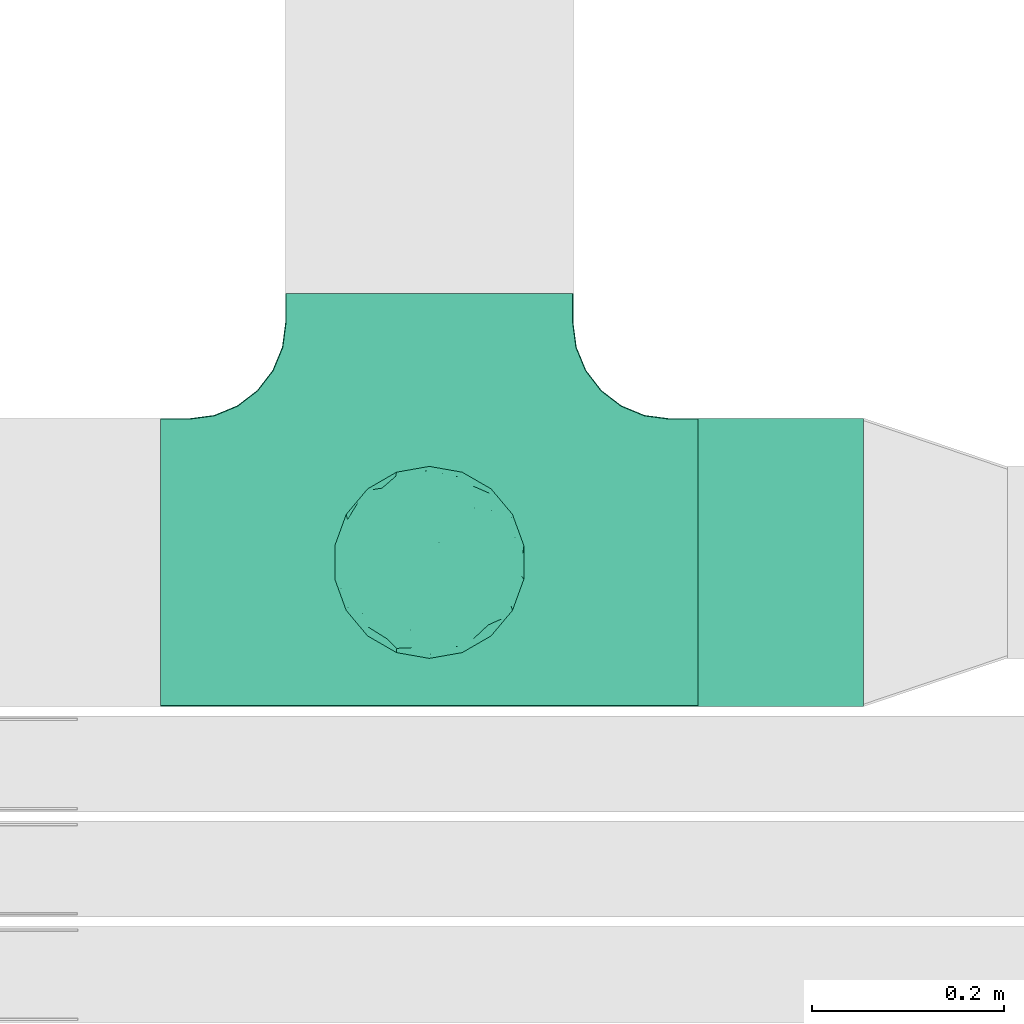
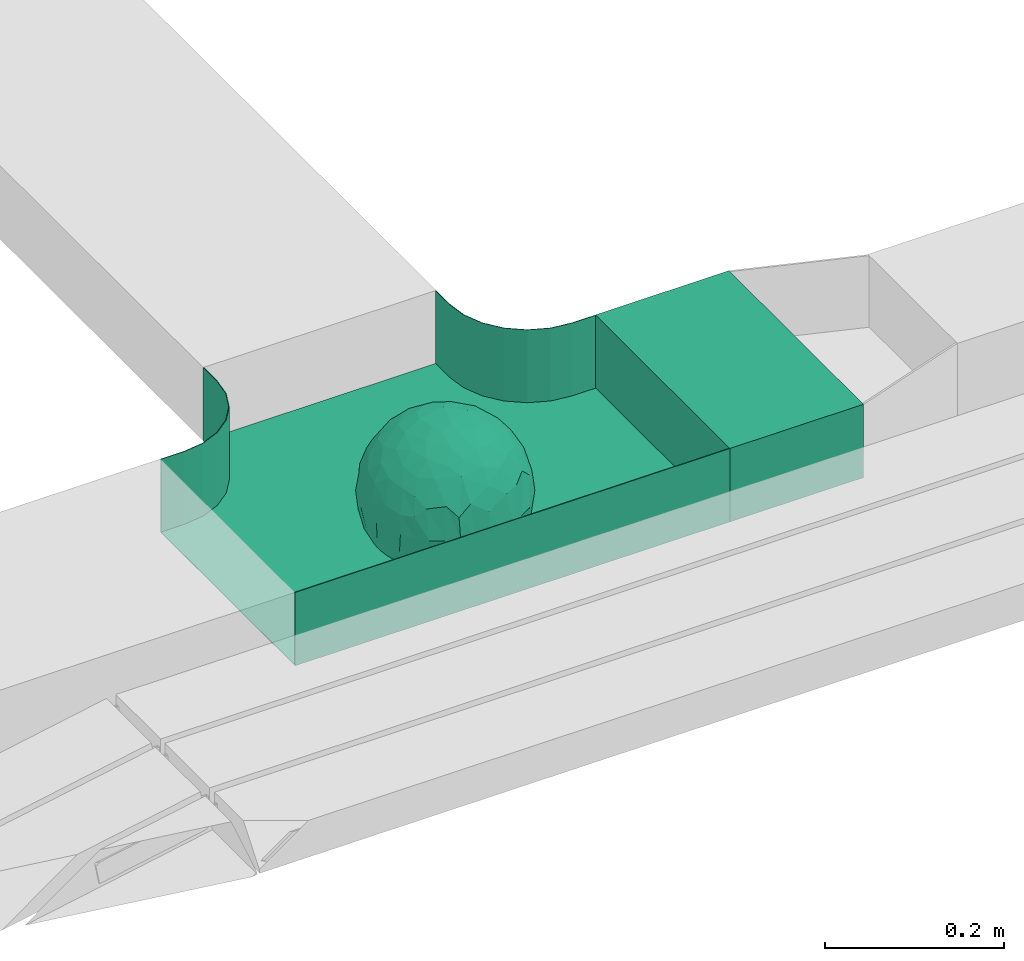
# One storey, part 12 of 33: 1 flow fitting, 1 flow segment.
"""IFC2X3 building model written with IfcOpenShell, lengths in millimetres."""

from ifc_helpers import new_model, entity, si_unit, converted_unit, derived_unit, direction, frame, frame_2d, origin, place, context, subcontext, project, spatial, rectangle, extrude, faceted_brep, source, transform, mapped, material, material_list, type_object, type_shapes, element, save


model = new_model("IFC2X3")

# Units and contexts
model_context = context("Model", 3, precision=0.01, world=origin(), true_north=direction((6.12303176911189e-17, 1.0)))
body_context = subcontext(model_context, "Body", "Model", "MODEL_VIEW")
ifc_project = project(units=[si_unit("LENGTHUNIT", "METRE", prefix="MILLI"), si_unit("AREAUNIT", "SQUARE_METRE"), si_unit("VOLUMEUNIT", "CUBIC_METRE"), converted_unit("PLANEANGLEUNIT", "DEGREE", entity("IfcRatioMeasure", 0.0174532925199433), si_unit("PLANEANGLEUNIT", "RADIAN"), dimensions=[0, 0, 0, 0, 0, 0, 0]), si_unit("MASSUNIT", "GRAM", prefix="KILO"), derived_unit("MASSDENSITYUNIT", [(si_unit("MASSUNIT", "GRAM", prefix="KILO"), 1), (si_unit("LENGTHUNIT", "METRE"), -3)]), derived_unit("MOMENTOFINERTIAUNIT", [(si_unit("LENGTHUNIT", "METRE"), 4)]), si_unit("TIMEUNIT", "SECOND"), si_unit("FREQUENCYUNIT", "HERTZ"), si_unit("THERMODYNAMICTEMPERATUREUNIT", "DEGREE_CELSIUS"), derived_unit("THERMALTRANSMITTANCEUNIT", [(si_unit("MASSUNIT", "GRAM", prefix="KILO"), 1), (si_unit("THERMODYNAMICTEMPERATUREUNIT", "KELVIN"), -1), (si_unit("TIMEUNIT", "SECOND"), -3)]), derived_unit("VOLUMETRICFLOWRATEUNIT", [(si_unit("LENGTHUNIT", "METRE"), 3), (si_unit("TIMEUNIT", "SECOND"), -1)]), derived_unit("MASSFLOWRATEUNIT", [(si_unit("MASSUNIT", "GRAM", prefix="KILO"), 1), (si_unit("TIMEUNIT", "SECOND"), -1)]), derived_unit("ROTATIONALFREQUENCYUNIT", [(si_unit("TIMEUNIT", "SECOND"), -1)]), si_unit("ELECTRICCURRENTUNIT", "AMPERE"), si_unit("ELECTRICVOLTAGEUNIT", "VOLT"), si_unit("POWERUNIT", "WATT"), si_unit("FORCEUNIT", "NEWTON", prefix="KILO"), si_unit("ILLUMINANCEUNIT", "LUX"), si_unit("LUMINOUSFLUXUNIT", "LUMEN"), si_unit("LUMINOUSINTENSITYUNIT", "CANDELA"), derived_unit("USERDEFINED", [(si_unit("MASSUNIT", "GRAM", prefix="KILO"), -1), (si_unit("LENGTHUNIT", "METRE"), -2), (si_unit("TIMEUNIT", "SECOND"), 3), (si_unit("LUMINOUSFLUXUNIT", "LUMEN"), 1)]), derived_unit("LINEARVELOCITYUNIT", [(si_unit("LENGTHUNIT", "METRE"), 1), (si_unit("TIMEUNIT", "SECOND"), -1)]), si_unit("PRESSUREUNIT", "PASCAL"), derived_unit("USERDEFINED", [(si_unit("LENGTHUNIT", "METRE"), -2), (si_unit("MASSUNIT", "GRAM", prefix="KILO"), 1), (si_unit("TIMEUNIT", "SECOND"), -2)]), derived_unit("LINEARFORCEUNIT", [(si_unit("MASSUNIT", "GRAM", prefix="KILO"), 1), (si_unit("LENGTHUNIT", "METRE"), 1), (si_unit("TIMEUNIT", "SECOND"), -2), (si_unit("LENGTHUNIT", "METRE"), -1)]), derived_unit("PLANARFORCEUNIT", [(si_unit("MASSUNIT", "GRAM", prefix="KILO"), 1), (si_unit("LENGTHUNIT", "METRE"), 1), (si_unit("TIMEUNIT", "SECOND"), -2), (si_unit("LENGTHUNIT", "METRE"), -2)])], contexts=[model_context])

# Site, building, storey
site_placement = place(None, frame((0.0, -0.00077364408347762, 0.0)))
site = spatial("IfcSite", under=ifc_project, at=site_placement, CompositionType="ELEMENT")
building_placement = place(site_placement, origin())
building = spatial("IfcBuilding", under=site, at=building_placement, CompositionType="ELEMENT")
storey_placement = place(building_placement, frame((0.0, 0.0, 8100.0)))
storey = spatial("IfcBuildingStorey", under=building, at=storey_placement, CompositionType="ELEMENT", Elevation=8100.0)

# Flow segment
cable_carrier_segment_type = type_object("IfcCableCarrierSegmentType", PredefinedType="CABLETRAYSEGMENT")
flow_segment_placement = place(storey_placement, frame((27371.0061453203, 9844.99855346682, 2800.0)))
element("IfcFlowSegment", 1, at=flow_segment_placement, inside=storey, type_object=cable_carrier_segment_type, context=body_context, shape_type="SweptSolid", body=[
    extrude(rectangle(XDim=172.000000000026, YDim=300.000000000001, at=frame_2d((2.16715534406831e-12, -1.08002495835535e-12), x_axis=(1.0, 0.0))), frame((86.0, 150.0, 0.0), z_axis=(0.0, 0.0, 1.0), x_axis=(-1.0, 0.0, 0.0)), (0.0, 0.0, 1.0), 99.9999999999989),
])

# Flow fitting
ifc_material_1 = material()
ifc_material_2 = material()
ifc_material_list = material_list([ifc_material_1, ifc_material_2])
cable_carrier_fitting_type = type_object("IfcCableCarrierFittingType", PredefinedType="NOTDEFINED", material=ifc_material_1)
shared_shape = source(origin(), body_context, "Body", "Brep", [
    faceted_brep([(76.4840203203325, -37.7983376575012, -52.1678090968869), (89.2874188526836, -26.168482477916, -36.6465190629256), (85.270060821053, -46.6341564571094, -23.5429857730317), (-17.2892276551183, -34.784102350051, -92.1474298653505), (3.07548730030541e-06, -44.1611501073546, -89.7206376548624), (-24.6383925717335, -51.5777741549417, -82.0529269721827), (76.3287929967882, -15.079107031813, -62.8214604317408), (55.5757044674811, -29.5498647779489, -77.7055118028838), (-17.1010071662778, 96.9846310392869, 0.0), (-18.6742130440203, 88.8859886245005, -41.8396318510259), (-33.8953581705111, 89.5312614551001, -28.9008289976074), (-45.4623263334585, -10.4806178463803, -88.4496101399357), (-19.8193717281607, 5.04030654129894, -97.8866069197874), (-23.6628375063711, -16.1276312747485, -95.8121580521565), (92.5416578398381, 33.6824088833379, 0.0), (85.2767902974019, 45.7715256118899, -25.1562413673598), (86.6025403784496, 50.0, 0.0), (49.240387650616, -85.2868531952529, 0.0), (62.2001900548409, -72.1916708642314, -30.3232421580155), (64.2787609686595, -76.6044443119063, 0.0), (97.1714774391015, -8.71557429474411, -21.948638614181), (90.7615649771405, 0.0, -41.9802134689751), (96.1413151932242, 14.3969945426304, -23.4429959914917), (98.4807753012265, 17.3648177666844, 0.0), (98.4807753012265, 0.0, 0.0), (79.0119763428423, 8.47783312434252, -60.7061276965826), (76.4840203202329, 37.7983376578076, -52.1678090967986), (87.696722672108, 23.4364088603614, -41.9525871943713), (29.163429357778, -37.5977865113054, -87.9539699930814), (20.3014061890807, -63.7692165377112, -74.3057193553274), (-69.6223300212076, 53.192794202726, -48.2001847229044), (-47.2059268691477, 56.745965379315, -67.4647751170325), (-61.603837577254, 43.4748411443104, -65.6879394046569), (29.4497539748763, 71.3200718492295, -63.6094280923684), (47.2059306757939, 56.745965229418, -67.4647725795649), (30.0444734578003, 49.6507498561999, -81.4379067348793), (-49.6683382574198, -77.0947032728586, -39.8680687018642), (-34.202014332561, -93.9692620785994, 0.0), (-49.2403876506046, -85.2868531952529, 0.0), (61.3953921577507, 65.1440685107005, -44.5741647108287), (74.6816445462022, 59.1436972034819, -30.4084700203242), (61.9457748290475, 44.5417169664605, -64.6433015130544), (28.7737714324073, -89.42049207415, -34.2935223442239), (34.2020143325724, -93.9692620785994, 0.0), (25.6515107494307, -95.4769465589517, 0.0), (17.101007166289, -96.9846310393039, 0.0), (-64.2787609686481, -76.6044443119063, 0.0), (-75.4406506735431, -63.3022221559575, 0.0), (-74.7500995498228, -61.5460620722206, -24.9900952517949), (7.49675578587143, -83.6888268592038, -54.2215723823823), (36.4863653716413, -70.367842623822, -60.9681217230515), (-76.4840178500364, -37.798342255337, -52.1678093872333), (-87.0716088907139, -22.4880335791362, -43.7358350889169), (-79.0617266871127, -6.53517927425345, -60.8813173732629), (63.5329768828015, 0.0, -77.2240949989638), (-63.5329752663337, -4.28405924068898e-09, -77.2240963288374), (-81.9271917640341, 16.0413321025015, -55.0509846781547), (-98.4807753012151, -17.3648177667017, 0.0), (-95.569577544237, -17.0482102820805, -23.9961324840668), (-92.5416578398266, -33.6824088833551, 0.0), (65.8639795091221, 23.4057144961932, -71.5129969456177), (-19.2962502251216, 70.2650181304482, -68.487093341555), (-44.3250940555787, 79.4239687498613, -41.5586239543935), (-76.4840178487499, 37.7983422512769, -52.1678093920491), (-45.0467119602772, 37.358552492076, -81.0871894768975), (-67.1951546795767, 22.414876352536, -70.586007860525), (45.8905780821677, 15.5420810523434, -87.478560572553), (-67.1382383390432, -22.457587679949, -70.6265793333204), (-97.6852110527561, 5.09344694659685, -20.7763408659754), (-90.761561927752, 1.63062869873443e-09, -41.9802200617526), (-92.5416578398267, 33.6824088833379, 0.0), (-92.1520232806737, 27.1973992873941, -27.7183346772189), (28.8657365411401, 87.5169428696254, -38.8272322563751), (7.49675578553467, 83.6888268595355, -54.2215723818906), (1.22951801366171, 95.7251008343745, -28.8997120349128), (3.5162183498022, -95.8354910731824, -28.3406926393789), (-8.55050358313599, -98.4923155196562, 0.0), (-12.2828353145794, -96.1465810571431, -24.5960750457924), (75.4406506735547, 63.3022221559403, 0.0), (64.2787609686598, 76.6044443118892, 0.0), (75.4406506735545, -63.3022221559575, 0.0), (86.6025403784495, -50.0, 0.0), (-75.4406506735433, 63.3022221559403, 0.0), (-84.8930621241031, 46.8074333743426, -24.5404193953063), (-86.6025403784383, 50.0, 0.0), (-65.6229030223494, -61.3889655017833, -43.8751582736728), (-47.2059268729136, -56.7459653834318, -67.4647751109489), (-85.2400449211107, -44.6766589600176, -27.1685642980393), (46.0205786918846, 37.1654843094529, -80.6277440643515), (-63.1788213480048, 67.6783588085196, -37.7898965605855), (-7.15444733827542, -67.6177156734158, -73.3257008857939), (31.5424765006817, -5.30265693589207, -94.7467888934671), (9.84735642755859, -20.4964224402077, -97.3803175109847), (1.0083019663368e-06, 13.3030981775211, -99.111187960177), (49.3513473168359, -11.1781440260195, -86.252499176233), (92.541657839838, -33.6824088833551, 0.0), (98.4807753012265, -17.3648177667017, 0.0), (49.2403876506163, 85.2868531952358, 0.0), (46.4041236261553, 79.1080859305986, -39.8568444672194), (34.2020143325727, 93.9692620785823, 0.0), (-53.1130236264114, 15.1205787052499, -83.3689079985849), (64.5322070769988, -54.17210261472, -53.8607236125959), (47.2059306758545, -56.745965228813, -67.4647725800455), (22.8875622085795, 27.5743091168824, -93.3585399032859), (74.6816445462803, -59.1436972033529, -30.4084700204161), (46.4041236262572, -79.108085930386, -39.8568444675565), (-15.7383008676665, 23.1933977335444, -95.9915214348144), (2.80963889519618, 33.9846447662373, -94.0061160211894), (9.20690877800443, 52.3900236205866, -84.6789126984153), (9.72607601259755, 69.7500364970203, -70.995322761851), (17.1010071662892, 96.9846310392869, 0.0), (-5.62154210059744, -90.1648531765776, -42.8800363346189), (0.0, -100.0, 0.0), (-25.1293295965289, -93.3686387308287, -25.5110582999201), (-25.949186528859, -84.8833009001169, -46.0593632912046), (-17.1010071662777, -96.9846310393039, 0.0), (-10.2354907319271, -80.7824512711375, -58.0467940208873), (-31.237630661844, -69.7640997378305, -64.4762035048911), (-42.1850269133029, -33.6354441712551, -84.1966768924114), (-35.781529361024, 18.547890266457, -91.5186206367184), (-61.619736792185, -43.523827571712, -65.6405703141646), (-17.3443611696694, 40.8888850191612, -89.595045719636), (-29.1001411816516, 55.690814260002, -77.7927695243168), (-10.6569193640809, 57.0342754657797, -81.4464332660353), (-59.774866149928, -75.5723898452015, -26.7540514659609), (-86.6025403784381, -50.0, 0.0), (-98.4807753012151, 0.0, 0.0), (-98.4807753012152, 17.3648177666844, 0.0), (-74.7670053246598, 60.7049605869996, -26.9221595513964), (-64.2787609686484, 76.6044443118892, 0.0), (-49.2403876506049, 85.2868531952358, 0.0), (-34.2020143325614, 93.9692620785823, 0.0), (0.0, 100.0, 0.0), (-76.484019526794, -37.798337198235, 52.1678105930665), (-89.2874185112873, -26.1684825046027, 36.6465198756512), (-85.2700607126513, -46.6341564521743, 23.5429861753997), (17.2892307880813, -34.7841011602588, 92.1474297266695), (-3.38734512270379e-07, -44.1611496359296, 89.720637886916), (24.6383956411536, -51.5777728113463, 82.0529268951053), (-76.3287917934888, -15.0791068021182, 62.8214619488982), (-55.5757026100472, -29.549864599369, 77.7055131992549), (18.6742091034424, 88.885990914275, 41.8396287453374), (33.8953586129312, 89.5312597468659, 28.9008337706599), (17.3443607633453, 40.8888810970192, 89.5950475882768), (15.7383028761951, 23.1933956687767, 95.9915216044101), (35.7815318404767, 18.5478901047313, 91.5186197001092), (-85.2767901734143, 45.7715256234335, 25.1562417666364), (-62.2001897574699, -72.1916707653145, 30.3232430034808), (-97.1714773187454, -8.71557427953189, 21.9486391530291), (-96.141315013212, 14.3969947624817, 23.4429965946852), (-79.0119753418501, 8.47783306286876, 60.7061290080075), (-76.4840195267832, 37.7983371982528, 52.1678105930571), (-87.6967222099395, 23.4364087722604, 41.9525882096856), (-29.163427099677, -37.5977868949179, 87.9539705778413), (-20.301404034393, -63.7692173365967, 74.305719258427), (69.6223307049661, 53.192787114506, 48.2001915577083), (47.2059293170501, 56.7459646829409, 67.4647739899622), (61.6038389573326, 43.4748357207471, 65.6879416999347), (-61.3953919237905, 65.1440676388516, 44.5741663072653), (49.2659552585237, -77.3488009806731, 39.8751631886295), (-74.681644350378, 59.1436969740875, 30.4084709474116), (-61.9457736264423, 44.5417164806275, 64.643303000237), (-7.49675472945651, -83.6888265867081, 54.2215729490431), (-36.486364416374, -70.367842442625, 60.968122503872), (-28.7737710558201, -89.4204919730988, 34.2935229236939), (74.7446466999101, -61.6521905333982, 24.7435889098862), (3.00446277704405, -95.5180690083503, 29.4494770130044), (-13.4675721353261, -92.748406770264, 34.876317786707), (76.4840204055964, -37.7983390347103, 52.167807974034), (87.0716107179514, -22.4880293497667, 43.7358336258448), (79.0617298359488, -6.53517466347878, 60.8813137790831), (-63.5329751791014, 0.0, 77.2240964006191), (63.5329772594296, 0.0, 77.2240946891232), (81.9271971902465, 16.0413321407425, 55.050976591722), (95.5695783977716, -17.0482115223089, 23.9961282036192), (-65.8639781491499, 23.405714160557, 71.5129983080176), (19.2962569358552, 70.2650237882598, 68.4870856461333), (44.3251010195622, 79.4239674638786, 41.5586189845396), (76.4840204055789, 37.7983390346199, 52.1678079741129), (45.0467113579588, 37.35855313631, 81.0871895147151), (67.1951616703757, 22.4148716107117, 70.5860027113649), (-45.8905758090763, 15.5420810346383, 87.4785617681537), (67.1382437930653, -22.4575840893256, 70.6265752904385), (97.6852138116852, 5.09344112492882, 20.7763293214556), (90.7615650780775, 0.0, 41.9802132507632), (92.1520274335419, 27.1973943799444, 27.7183256859159), (-28.8657360653296, 87.5169427229152, 38.8272329408042), (-7.49675472951015, 83.6888265867653, 54.2215729489213), (-1.22952463606755, 95.725101063195, 28.8997109952541), (7.15445060231028, -67.6177152767913, 73.3257009330848), (30.0445391888188, -71.0236195697132, 63.6629494144802), (-90.7615645164956, 0.0, 41.9802144648834), (84.8930644946618, 46.8074299509675, 24.5404177244603), (65.657396767693, -61.8519680594647, 43.1675838664051), (47.2059293174508, -56.7459646832734, 67.4647739894163), (85.240045822543, -44.6766582374337, 27.1685626581248), (-30.0444712047215, 49.6507502843406, 81.4379073050796), (-47.2059295896367, 56.7459650911412, 67.4647734558766), (-46.0205764805425, 37.1654842487523, 80.6277453545262), (63.1788267861392, 67.6783521071165, 37.7898994705241), (-31.542473908998, -5.30265693887445, 94.7467897561175), (-9.84735391303847, -20.4964227184575, 97.3803177067078), (1.34873765353802e-06, 13.3030991109957, 99.1111878348972), (-49.3513452292634, -11.1781439777262, 86.2525003769525), (-46.4041232356316, 79.1080858261746, 39.8568451291574), (-29.4497536788485, 71.3200715314942, 63.609428585683), (24.3100719261245, -93.7923353358836, 24.7390023078953), (-64.5322063997089, -54.1721023527289, 53.8607246875848), (-47.2059295895764, -56.7459650910276, 67.4647734560286), (-22.8875602129064, 27.5743087068143, 93.3585405136699), (-46.4041232356225, -79.1080858261415, 39.8568451292672), (-74.6816443503883, -59.1436969740864, 30.408470947421), (19.8193741532226, 5.04030693924503, 97.8866064083047), (-2.80963679644177, 33.9846454726014, 94.0061158285697), (-9.20690598859987, 52.3900245858364, 84.6789124045226), (-9.72607582248976, 69.7500367089908, 70.9953225796557), (9.6507963138497, -80.5368358032807, 58.4865814465705), (23.4705761898964, -86.311306248728, 44.7156624344864), (35.1118074315221, -89.6215726748419, 27.113367370765), (42.1850318693192, -33.6354421467953, 84.1966752180655), (23.6628407100174, -16.1276300406404, 95.8121574686978), (45.4623290073054, -10.4806171517165, 88.4496088479348), (61.6197386049218, -43.5238234805734, 65.6405713251752), (29.1001407425045, 55.6908137196801, 77.7927700754181), (10.6569061579526, 57.0342796833114, 81.4464320406166), (59.3537179746501, -75.8188405832575, 26.9933246414488), (74.7670061544982, 60.7049632941286, 26.9221511427291), (53.1130277137063, 15.1205817594398, 83.3689048407183)], [[[0, 1, 2]], [[3, 4, 5]], [[6, 0, 7]], [[8, 9, 10]], [[11, 12, 13]], [[14, 15, 16]], [[17, 18, 19]], [[20, 21, 22]], [[22, 23, 24]], [[25, 26, 27]], [[4, 28, 29]], [[30, 31, 32]], [[33, 34, 35]], [[36, 37, 38]], [[39, 40, 41]], [[42, 43, 44, 45]], [[46, 47, 48]], [[49, 50, 42]], [[51, 52, 53]], [[54, 25, 6]], [[55, 53, 56]], [[57, 58, 59]], [[26, 25, 60]], [[61, 31, 62]], [[32, 63, 30]], [[64, 65, 32]], [[54, 66, 60]], [[53, 67, 51]], [[58, 68, 69]], [[68, 70, 71]], [[72, 73, 74]], [[75, 76, 77]], [[6, 7, 54]], [[24, 20, 22]], [[78, 40, 79]], [[15, 26, 40]], [[1, 21, 20]], [[80, 2, 81]], [[63, 56, 71]], [[82, 83, 84]], [[36, 85, 86]], [[87, 58, 52]], [[35, 34, 88]], [[62, 31, 89]], [[42, 75, 49]], [[4, 29, 90]], [[91, 92, 93]], [[7, 94, 54]], [[6, 1, 0]], [[95, 81, 2]], [[24, 96, 20]], [[1, 20, 95]], [[1, 95, 2]], [[27, 22, 21]], [[15, 14, 22]], [[25, 27, 21]], [[15, 78, 16]], [[41, 40, 26]], [[40, 78, 15]], [[39, 97, 79]], [[97, 98, 99]], [[40, 39, 79]], [[33, 73, 72]], [[21, 1, 6]], [[25, 54, 60]], [[64, 100, 65]], [[26, 15, 27]], [[6, 25, 21]], [[0, 101, 7]], [[102, 28, 7]], [[92, 91, 28]], [[94, 28, 91]], [[88, 34, 41]], [[54, 94, 66]], [[41, 26, 60]], [[103, 91, 93]], [[88, 41, 60]], [[20, 96, 95]], [[101, 18, 102]], [[104, 80, 19]], [[101, 0, 104]], [[18, 105, 102]], [[43, 42, 105]], [[17, 43, 105]], [[29, 28, 102]], [[28, 4, 92]], [[105, 50, 102]], [[90, 29, 49]], [[88, 60, 66]], [[41, 34, 39]], [[34, 98, 39]], [[97, 39, 98]], [[103, 66, 91]], [[88, 66, 103]], [[12, 106, 93]], [[33, 98, 34]], [[107, 103, 93]], [[35, 103, 108]], [[103, 35, 88]], [[33, 109, 73]], [[109, 35, 108]], [[110, 72, 74]], [[72, 110, 99]], [[98, 33, 72]], [[99, 98, 72]], [[80, 104, 2]], [[0, 2, 104]], [[101, 104, 18]], [[7, 101, 102]], [[19, 18, 104]], [[105, 18, 17]], [[77, 111, 75]], [[75, 45, 112]], [[113, 114, 111]], [[115, 77, 76]], [[36, 114, 37]], [[90, 5, 4]], [[75, 42, 45]], [[50, 49, 29]], [[49, 116, 90]], [[5, 117, 86]], [[90, 116, 117]], [[118, 13, 3]], [[118, 5, 86]], [[11, 119, 12]], [[67, 120, 51]], [[11, 13, 118]], [[65, 55, 56]], [[121, 122, 123]], [[90, 117, 5]], [[51, 120, 85]], [[117, 36, 86]], [[36, 117, 114]], [[46, 48, 124]], [[38, 124, 36]], [[85, 124, 48]], [[87, 125, 59]], [[125, 87, 47]], [[48, 51, 85]], [[68, 57, 126, 127]], [[59, 58, 87]], [[58, 69, 52]], [[53, 52, 69]], [[87, 52, 51]], [[56, 53, 69]], [[53, 55, 67]], [[71, 56, 69]], [[56, 63, 65]], [[71, 69, 68]], [[128, 129, 89]], [[11, 67, 55]], [[120, 118, 86]], [[32, 65, 63]], [[100, 55, 65]], [[118, 120, 67]], [[85, 120, 86]], [[129, 128, 82]], [[64, 32, 31]], [[62, 130, 131]], [[130, 62, 89]], [[9, 73, 61]], [[10, 62, 131]], [[109, 61, 73]], [[73, 9, 74]], [[64, 121, 119]], [[122, 61, 123]], [[64, 119, 100]], [[64, 31, 122]], [[107, 108, 103]], [[47, 87, 48]], [[51, 48, 87]], [[57, 68, 58]], [[64, 122, 121]], [[89, 129, 130]], [[67, 11, 118]], [[11, 55, 100]], [[82, 128, 83]], [[30, 128, 89]], [[83, 63, 71]], [[63, 83, 128]], [[84, 83, 71]], [[10, 61, 62]], [[74, 8, 132]], [[8, 74, 9]], [[110, 74, 132]], [[3, 92, 4]], [[92, 13, 12]], [[22, 27, 15]], [[14, 23, 22]], [[11, 100, 119]], [[128, 30, 63]], [[31, 30, 89]], [[28, 94, 7]], [[66, 94, 91]], [[42, 50, 105]], [[29, 102, 50]], [[106, 107, 93]], [[123, 107, 121]], [[35, 109, 33]], [[109, 108, 123]], [[75, 112, 76]], [[113, 77, 115]], [[114, 116, 111]], [[115, 37, 113]], [[37, 114, 113]], [[49, 75, 111]], [[117, 116, 114]], [[111, 77, 113]], [[49, 111, 116]], [[118, 3, 5]], [[92, 3, 13]], [[106, 119, 121]], [[92, 12, 93]], [[119, 106, 12]], [[107, 106, 121]], [[46, 124, 38]], [[85, 36, 124]], [[70, 68, 127]], [[70, 84, 71]], [[31, 61, 122]], [[109, 123, 61]], [[107, 123, 108]], [[8, 10, 131]], [[61, 10, 9]], [[133, 134, 135]], [[136, 137, 138]], [[139, 133, 140]], [[110, 141, 142]], [[143, 144, 145]], [[70, 146, 84]], [[38, 147, 46]], [[126, 57, 148]], [[149, 127, 126]], [[150, 151, 152]], [[137, 153, 154]], [[155, 156, 157]], [[130, 129, 158]], [[159, 43, 17]], [[158, 160, 161]], [[162, 163, 164]], [[19, 80, 165]], [[166, 167, 115]], [[168, 169, 170]], [[171, 150, 139]], [[172, 170, 173]], [[96, 174, 95]], [[151, 150, 175]], [[176, 156, 177]], [[157, 178, 155]], [[179, 180, 157]], [[171, 181, 175]], [[170, 182, 168]], [[174, 183, 184]], [[185, 23, 14, 16]], [[186, 187, 188]], [[138, 189, 190]], [[139, 140, 171]], [[126, 148, 149]], [[82, 160, 129]], [[146, 151, 160]], [[134, 191, 148]], [[47, 135, 125]], [[178, 173, 185]], [[78, 192, 16]], [[159, 193, 194]], [[195, 174, 169]], [[196, 197, 198]], [[177, 156, 199]], [[166, 112, 45]], [[154, 189, 137]], [[200, 201, 202]], [[140, 203, 171]], [[191, 149, 148]], [[59, 125, 135]], [[133, 139, 134]], [[134, 148, 59]], [[134, 59, 135]], [[152, 149, 191]], [[146, 70, 149]], [[150, 152, 191]], [[146, 82, 84]], [[161, 160, 151]], [[160, 82, 146]], [[204, 131, 130]], [[186, 205, 187]], [[160, 158, 129]], [[197, 196, 205]], [[191, 134, 139]], [[150, 171, 175]], [[45, 206, 166]], [[151, 146, 152]], [[139, 150, 191]], [[133, 207, 140]], [[208, 153, 140]], [[201, 200, 153]], [[203, 153, 200]], [[198, 197, 161]], [[171, 203, 181]], [[161, 151, 175]], [[209, 200, 202]], [[198, 161, 175]], [[148, 57, 59]], [[38, 37, 210]], [[211, 47, 46]], [[207, 133, 211]], [[147, 210, 208]], [[210, 37, 164]], [[208, 207, 147]], [[154, 153, 208]], [[153, 137, 201]], [[210, 163, 208]], [[189, 154, 162]], [[198, 175, 181]], [[161, 197, 158]], [[197, 204, 158]], [[130, 158, 204]], [[209, 181, 200]], [[198, 181, 209]], [[212, 144, 202]], [[205, 204, 197]], [[213, 209, 202]], [[196, 209, 214]], [[209, 196, 198]], [[205, 215, 187]], [[215, 196, 214]], [[8, 186, 188]], [[186, 8, 131]], [[204, 205, 186]], [[131, 204, 186]], [[47, 211, 135]], [[133, 135, 211]], [[207, 211, 147]], [[140, 207, 208]], [[46, 147, 211]], [[210, 147, 38]], [[166, 115, 76, 112]], [[115, 164, 37]], [[163, 162, 154]], [[216, 166, 217]], [[138, 137, 189]], [[162, 216, 189]], [[218, 44, 43]], [[44, 218, 206]], [[189, 216, 190]], [[219, 220, 136]], [[219, 138, 194]], [[221, 145, 212]], [[182, 222, 168]], [[221, 220, 219]], [[180, 172, 173]], [[143, 223, 224]], [[168, 222, 193]], [[194, 138, 190]], [[190, 159, 194]], [[190, 217, 218]], [[19, 165, 225]], [[17, 225, 159]], [[193, 225, 165]], [[195, 81, 95]], [[81, 195, 80]], [[165, 168, 193]], [[183, 96, 24, 23]], [[95, 174, 195]], [[174, 184, 169]], [[170, 169, 184]], [[195, 169, 168]], [[173, 170, 184]], [[170, 172, 182]], [[185, 173, 184]], [[173, 178, 180]], [[185, 184, 183]], [[226, 79, 199]], [[221, 182, 172]], [[222, 219, 194]], [[157, 180, 178]], [[227, 172, 180]], [[219, 222, 182]], [[193, 222, 194]], [[79, 226, 78]], [[179, 157, 156]], [[177, 97, 99]], [[97, 177, 199]], [[141, 187, 176]], [[142, 177, 99]], [[215, 176, 187]], [[187, 141, 188]], [[179, 143, 145]], [[223, 176, 224]], [[179, 145, 227]], [[179, 156, 223]], [[213, 214, 209]], [[96, 183, 174]], [[185, 183, 23]], [[80, 195, 165]], [[168, 165, 195]], [[199, 79, 97]], [[182, 221, 219]], [[221, 172, 227]], [[78, 226, 192]], [[155, 226, 199]], [[192, 178, 185]], [[178, 192, 226]], [[16, 192, 185]], [[142, 176, 177]], [[188, 110, 132]], [[110, 188, 141]], [[8, 188, 132]], [[136, 201, 137]], [[201, 220, 212]], [[149, 152, 146]], [[70, 127, 149]], [[167, 162, 164]], [[179, 227, 180]], [[221, 227, 145]], [[226, 155, 178]], [[156, 155, 199]], [[153, 203, 140]], [[181, 203, 200]], [[164, 163, 210]], [[154, 208, 163]], [[144, 213, 202]], [[224, 213, 143]], [[196, 215, 205]], [[215, 214, 224]], [[166, 216, 162]], [[190, 216, 217]], [[218, 217, 206]], [[43, 159, 218]], [[190, 218, 159]], [[166, 206, 217]], [[44, 206, 45]], [[219, 136, 138]], [[201, 136, 220]], [[201, 212, 202]], [[221, 212, 220]], [[145, 144, 212]], [[213, 144, 143]], [[19, 225, 17]], [[193, 159, 225]], [[179, 223, 143]], [[156, 176, 223]], [[215, 224, 176]], [[213, 224, 214]], [[110, 142, 99]], [[176, 142, 141]], [[115, 167, 164]], [[166, 162, 167]]]),
    faceted_brep([(-153.407417371086, -224.118095489753, 50.0), (-150.0, -250.0, 50.0), (-150.0, -280.0, 50.0), (-149.199999999993, -280.0, 50.0), (-149.199999999993, -250.0, 50.0), (-152.634676710055, -223.911040253671, 50.0), (-162.704639298522, -199.600000000004, 50.0), (-178.723636456391, -178.7236364564, 50.0), (-199.599999999996, -162.704639298532, 50.0), (-223.911040253663, -152.634676710066, 50.0), (-250.0, -149.200000000004, 50.0), (-280.0, -149.200000000004, 50.0), (-280.0, -150.0, 50.0), (-250.0, -150.0, 50.0), (-224.118095489745, -153.407417371099, 50.0), (-200.0, -163.397459621561, 50.0), (-179.28932188134, -179.289321881349, 50.0), (-163.39745962155, -200.0, 50.0), (280.0, -150.0, 50.0), (280.0, -149.200000000004, 50.0), (250.0, -149.200000000007, 50.0), (223.911040253719, -152.634676710068, 50.0), (199.600000000048, -162.704639298534, 50.0), (178.723636456437, -178.7236364564, 50.0), (162.70463929856, -199.600000000004, 50.0), (152.634676710083, -223.91104025367, 50.0), (149.200000000009, -250.0, 50.0), (149.200000000007, -280.0, 50.0), (150.0, -280.0, 50.0), (150.0, -250.0, 50.0), (153.407417371116, -224.118095489752, 50.0), (163.39745962159, -200.0, 50.0), (179.289321881388, -179.289321881351, 50.0), (200.0, -163.397459621564, 50.0), (224.118095489802, -153.407417371102, 50.0), (250.0, -150.0, 50.0), (280.0, 149.199999999995, 50.0), (280.0, 150.0, 50.0), (-280.0, 150.0, 50.0), (-280.0, 149.199999999995, 50.0), (-280.0, -150.0, -50.0), (-280.0, 150.0, -50.0), (280.0, 150.0, -50.0), (280.0, -150.0, -50.0), (250.0, -150.0, -50.0), (224.118095489802, -153.407417371102, -50.0), (200.0, -163.397459621564, -50.0), (179.289321881388, -179.289321881351, -50.0), (163.39745962159, -200.0, -50.0), (153.407417371116, -224.118095489752, -50.0), (150.0, -250.0, -50.0), (150.0, -280.0, -50.0), (-150.0, -280.0, -50.0), (-150.0, -250.0, -50.0), (-153.407417371086, -224.118095489753, -50.0), (-163.39745962155, -200.0, -50.0), (-179.28932188134, -179.289321881349, -50.0), (-200.0, -163.397459621561, -50.0), (-224.118095489745, -153.407417371099, -50.0), (-250.0, -150.0, -50.0), (-150.0, -250.0, -49.1999999999851), (149.200000000007, -280.0, -49.1999999999851), (-149.199999999993, -280.0, -49.1999999999851), (-149.199999999993, -250.0, -49.1999999999851), (-250.0, -149.200000000004, -49.1999999999851), (-280.0, -149.200000000004, -49.1999999999851), (280.0, -149.200000000004, -49.1999999999851), (250.0, -149.200000000004, -49.1999999999851), (-280.0, 149.199999999995, -49.1999999999851), (-250.0, -150.0, -49.1999999999851), (250.0, -150.0, -49.1999999999851), (280.0, 149.199999999995, -49.1999999999851), (149.200000000009, -250.0, -49.1999999999851), (150.0, -250.0, -49.1999999999851), (-223.911040253663, -152.634676710066, -49.1999999999851), (-199.599999999996, -162.704639298532, -49.1999999999851), (-178.723636456391, -178.7236364564, -49.1999999999851), (-162.704639298522, -199.600000000004, -49.1999999999851), (-152.634676710055, -223.911040253671, -49.1999999999851), (152.634676710083, -223.911040253671, -49.1999999999851), (162.70463929856, -199.600000000004, -49.1999999999851), (178.723636456436, -178.723636456401, -49.1999999999851), (199.600000000047, -162.704639298534, -49.1999999999851), (223.911040253719, -152.634676710069, -49.1999999999851)], [[[0, 1, 2, 3, 4, 5, 6, 7, 8, 9, 10, 11, 12, 13, 14, 15, 16, 17]], [[18, 19, 20, 21, 22, 23, 24, 25, 26, 27, 28, 29, 30, 31, 32, 33, 34, 35]], [[36, 37, 38, 39]], [[40, 41, 42, 43, 44, 45, 46, 47, 48, 49, 50, 51, 52, 53, 54, 55, 56, 57, 58, 59]], [[2, 1, 60, 53, 52]], [[3, 2, 52, 51, 28, 27, 61, 62]], [[4, 3, 62, 63]], [[11, 10, 64, 65]], [[20, 19, 66, 67]], [[39, 38, 41, 40, 12, 11, 65, 68]], [[13, 12, 40, 59, 69]], [[18, 35, 70, 44, 43]], [[19, 18, 43, 42, 37, 36, 71, 66]], [[27, 26, 72, 61]], [[29, 28, 51, 50, 73]], [[38, 37, 42, 41]], [[36, 39, 68, 71]], [[68, 65, 64, 74, 75, 76, 77, 78, 63, 62, 61, 72, 79, 80, 81, 82, 83, 67, 66, 71]], [[14, 13, 69, 59, 58]], [[15, 14, 58, 57]], [[57, 56, 16, 15]], [[17, 16, 56, 55]], [[0, 17, 55, 54]], [[1, 0, 54, 53, 60]], [[5, 78, 77, 6]], [[6, 77, 76, 7]], [[63, 78, 5, 4]], [[8, 75, 74, 9]], [[9, 74, 64, 10]], [[7, 76, 75, 8]], [[21, 83, 82, 22]], [[22, 82, 81, 23]], [[67, 83, 21, 20]], [[24, 80, 79, 25]], [[25, 79, 72, 26]], [[23, 81, 80, 24]], [[30, 29, 73, 50, 49]], [[31, 30, 49, 48]], [[32, 31, 48, 47]], [[34, 33, 46, 45]], [[34, 45, 44, 70, 35]], [[46, 33, 32, 47]]]),
])
type_shapes(cable_carrier_fitting_type, [shared_shape])
flow_fitting_placement = place(storey_placement, frame((27091.0061453203, 9994.99855346683, 2850.0), z_axis=(0.0, 0.0, 1.0), x_axis=(-1.0, 0.0, 0.0)))
element("IfcFlowFitting", 2, at=flow_fitting_placement, inside=storey, type_object=cable_carrier_fitting_type, material=ifc_material_list, Name="470_DKC_S5_T", context=body_context, shape_type="MappedRepresentation", body=[
    mapped(shared_shape, transform((0.0, 0.0, 0.0), scale=1.0)),
])

save(model, "model.ifc")
